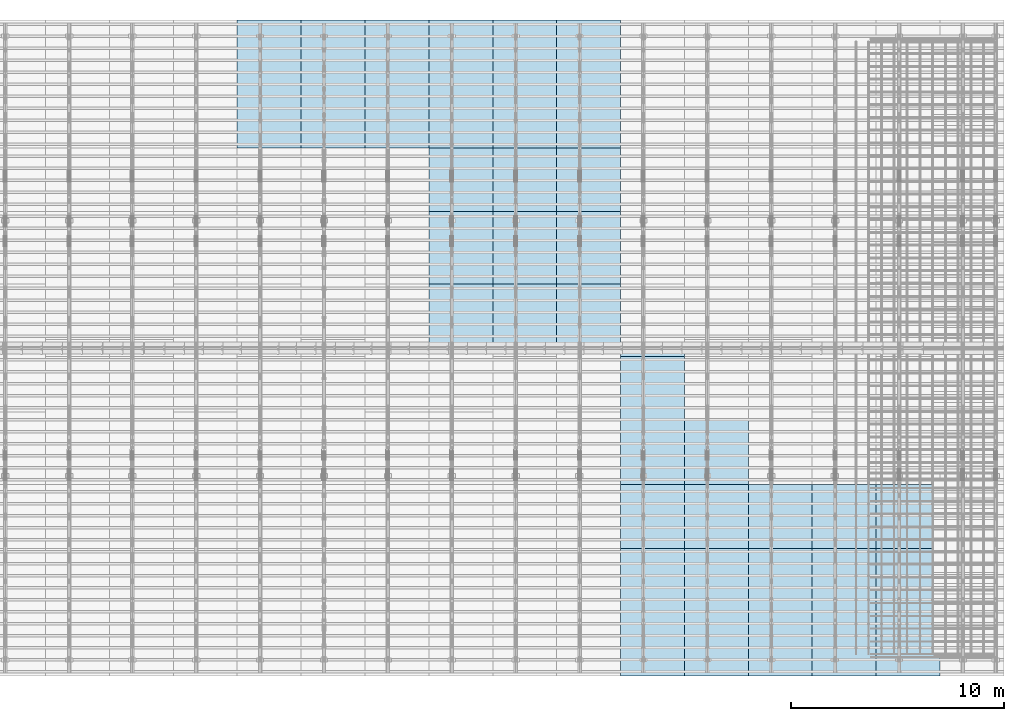
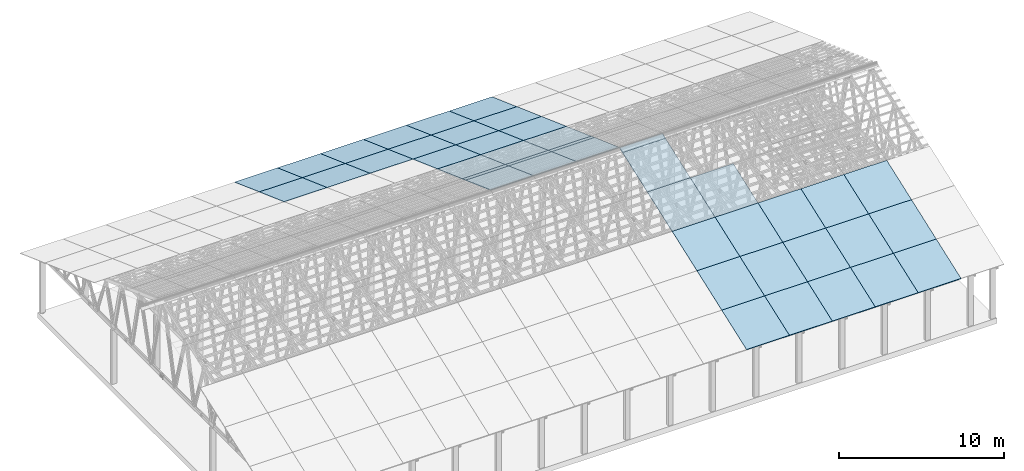
# One storey, part 8 of 189: 43 slabs, 43 elements without a shape of their own.
"""IFC2X3 building model written with IfcOpenShell, lengths in millimetres."""

from ifc_helpers import new_model, entity, si_unit, converted_unit, derived_unit, direction, frame, frame_2d, origin, place, context, subcontext, project, spatial, rectangle, extrude, material, layer, layer_set, element, aggregate, save


model = new_model("IFC2X3")

# Units and contexts
model_context = context("Model", 3, precision=0.01, world=origin(), true_north=direction((6.12303176911189e-17, 1.0)))
body_context = subcontext(model_context, "Body", "Model", "MODEL_VIEW")
ifc_project = project(units=[si_unit("LENGTHUNIT", "METRE", prefix="MILLI"), si_unit("AREAUNIT", "SQUARE_METRE"), si_unit("VOLUMEUNIT", "CUBIC_METRE"), converted_unit("PLANEANGLEUNIT", "DEGREE", entity("IfcRatioMeasure", 0.0174532925199433), si_unit("PLANEANGLEUNIT", "RADIAN"), dimensions=[0, 0, 0, 0, 0, 0, 0]), si_unit("MASSUNIT", "GRAM", prefix="KILO"), derived_unit("MASSDENSITYUNIT", [(si_unit("MASSUNIT", "GRAM", prefix="KILO"), 1), (si_unit("LENGTHUNIT", "METRE"), -3)]), si_unit("TIMEUNIT", "SECOND"), si_unit("FREQUENCYUNIT", "HERTZ"), si_unit("THERMODYNAMICTEMPERATUREUNIT", "DEGREE_CELSIUS"), derived_unit("THERMALTRANSMITTANCEUNIT", [(si_unit("MASSUNIT", "GRAM", prefix="KILO"), 1), (si_unit("THERMODYNAMICTEMPERATUREUNIT", "KELVIN"), -1), (si_unit("TIMEUNIT", "SECOND"), -3)]), derived_unit("VOLUMETRICFLOWRATEUNIT", [(si_unit("LENGTHUNIT", "METRE"), 3), (si_unit("TIMEUNIT", "SECOND"), -1)]), si_unit("ELECTRICCURRENTUNIT", "AMPERE"), si_unit("ELECTRICVOLTAGEUNIT", "VOLT"), si_unit("POWERUNIT", "WATT"), si_unit("FORCEUNIT", "NEWTON"), si_unit("ILLUMINANCEUNIT", "LUX"), si_unit("LUMINOUSFLUXUNIT", "LUMEN"), si_unit("LUMINOUSINTENSITYUNIT", "CANDELA"), derived_unit("USERDEFINED", [(si_unit("MASSUNIT", "GRAM", prefix="KILO"), -1), (si_unit("LENGTHUNIT", "METRE"), -2), (si_unit("TIMEUNIT", "SECOND"), 3), (si_unit("LUMINOUSFLUXUNIT", "LUMEN"), 1)]), derived_unit("LINEARVELOCITYUNIT", [(si_unit("LENGTHUNIT", "METRE"), 1), (si_unit("TIMEUNIT", "SECOND"), -1)]), si_unit("PRESSUREUNIT", "PASCAL"), derived_unit("USERDEFINED", [(si_unit("LENGTHUNIT", "METRE"), -2), (si_unit("MASSUNIT", "GRAM", prefix="KILO"), 1), (si_unit("TIMEUNIT", "SECOND"), -2)])], contexts=[model_context])

# Site, building, storey
site_placement = place(None, origin())
site = spatial("IfcSite", under=ifc_project, at=site_placement, CompositionType="ELEMENT")
building_placement = place(site_placement, origin())
building = spatial("IfcBuilding", under=site, at=building_placement, CompositionType="ELEMENT")
storey_placement = place(building_placement, origin())
storey = spatial("IfcBuildingStorey", under=building, at=storey_placement, Name="Default", CompositionType="ELEMENT", Elevation=0.0)

# Roof, slab
roof_1_placement = place(storey_placement, frame((44153.4200853155, -652.222549250817, 238.115215731819)))
roof_1 = element("IfcRoof", 1, at=roof_1_placement, inside=storey, ShapeType="NOTDEFINED")
ifc_material = material()
ifc_layer = layer(ifc_material, 40.0)
ifc_layer_set = layer_set([ifc_layer])
slab_1_placement = place(roof_1_placement, origin())
slab_1 = element("IfcSlab", 2, at=slab_1_placement, material=ifc_layer_set, PredefinedType="ROOF", context=body_context, shape_type="SweptSolid", body=[
    extrude(rectangle(XDim=3192.53331742773, YDim=2999.99999999999, at=frame_2d((0.0, -3.41060513164848e-13), x_axis=(0.0, -1.0))), frame((1500.0, 1500.0, 545.955351399302), z_axis=(0.0, -0.342020143325668, 0.939692620785909), x_axis=(1.0, 0.0, 0.0)), (0.0, 0.342020143325668, 0.939692620785909), 42.5671108990364),
])
aggregate(roof_1, [slab_1])

roof_2_placement = place(storey_placement, frame((44153.4200853155, 2347.77745074918, 1330.02591853042)))
roof_2 = element("IfcRoof", 3, at=roof_2_placement, inside=storey, ShapeType="NOTDEFINED")
slab_2_placement = place(roof_2_placement, origin())
slab_2 = element("IfcSlab", 4, at=slab_2_placement, material=ifc_layer_set, PredefinedType="ROOF", context=body_context, shape_type="SweptSolid", body=[
    extrude(rectangle(XDim=3192.53331742773, YDim=2999.99999999999, at=frame_2d((0.0, -1.13686837721616e-13), x_axis=(0.0, -1.0))), frame((1500.0, 1500.0, 545.955351399302), z_axis=(0.0, -0.342020143325668, 0.939692620785909), x_axis=(1.0, 0.0, 0.0)), (0.0, 0.342020143325668, 0.939692620785909), 42.5671108990353),
])
aggregate(roof_2, [slab_2])

roof_3_placement = place(storey_placement, frame((44153.4200853155, 5347.77745074918, 2421.93662132902)))
roof_3 = element("IfcRoof", 5, at=roof_3_placement, inside=storey, ShapeType="NOTDEFINED")
slab_3_placement = place(roof_3_placement, origin())
slab_3 = element("IfcSlab", 6, at=slab_3_placement, material=ifc_layer_set, PredefinedType="ROOF", context=body_context, shape_type="SweptSolid", body=[
    extrude(rectangle(XDim=3192.53331742773, YDim=2999.99999999999, at=frame_2d((0.0, 0.0), x_axis=(0.0, -1.0))), frame((1500.0, 1500.0, 545.955351399302), z_axis=(0.0, -0.342020143325668, 0.939692620785909), x_axis=(1.0, 0.0, 0.0)), (0.0, 0.342020143325668, 0.939692620785909), 42.5671108990355),
])
aggregate(roof_3, [slab_3])

roof_4_placement = place(storey_placement, frame((41153.4200853155, -652.222549250808, 238.115215731819)))
roof_4 = element("IfcRoof", 7, at=roof_4_placement, inside=storey, ShapeType="NOTDEFINED")
slab_4_placement = place(roof_4_placement, origin())
slab_4 = element("IfcSlab", 8, at=slab_4_placement, material=ifc_layer_set, PredefinedType="ROOF", context=body_context, shape_type="SweptSolid", body=[
    extrude(rectangle(XDim=3192.53331742773, YDim=2999.99999999999, at=frame_2d((0.0, -3.41060513164848e-13), x_axis=(0.0, -1.0))), frame((1500.0, 1500.0, 545.955351399302), z_axis=(0.0, -0.342020143325668, 0.939692620785909), x_axis=(1.0, 0.0, 0.0)), (0.0, 0.342020143325668, 0.939692620785909), 42.5671108990364),
])
aggregate(roof_4, [slab_4])

roof_5_placement = place(storey_placement, frame((41153.4200853155, 2347.77745074919, 1330.02591853042)))
roof_5 = element("IfcRoof", 9, at=roof_5_placement, inside=storey, ShapeType="NOTDEFINED")
slab_5_placement = place(roof_5_placement, origin())
slab_5 = element("IfcSlab", 10, at=slab_5_placement, material=ifc_layer_set, PredefinedType="ROOF", context=body_context, shape_type="SweptSolid", body=[
    extrude(rectangle(XDim=3192.53331742773, YDim=2999.99999999999, at=frame_2d((0.0, -1.13686837721616e-13), x_axis=(0.0, -1.0))), frame((1500.0, 1500.0, 545.955351399302), z_axis=(0.0, -0.342020143325668, 0.939692620785909), x_axis=(1.0, 0.0, 0.0)), (0.0, 0.342020143325668, 0.939692620785909), 42.5671108990353),
])
aggregate(roof_5, [slab_5])

roof_6_placement = place(storey_placement, frame((41153.4200853155, 5347.77745074919, 2421.93662132902)))
roof_6 = element("IfcRoof", 11, at=roof_6_placement, inside=storey, ShapeType="NOTDEFINED")
slab_6_placement = place(roof_6_placement, origin())
slab_6 = element("IfcSlab", 12, at=slab_6_placement, material=ifc_layer_set, PredefinedType="ROOF", context=body_context, shape_type="SweptSolid", body=[
    extrude(rectangle(XDim=3192.53331742773, YDim=2999.99999999999, at=frame_2d((0.0, 0.0), x_axis=(0.0, -1.0))), frame((1500.0, 1500.0, 545.955351399302), z_axis=(0.0, -0.342020143325668, 0.939692620785909), x_axis=(1.0, 0.0, 0.0)), (0.0, 0.342020143325668, 0.939692620785909), 42.5671108990355),
])
aggregate(roof_6, [slab_6])

roof_7_placement = place(storey_placement, frame((38153.4200853155, -652.222549250799, 238.115215731819)))
roof_7 = element("IfcRoof", 13, at=roof_7_placement, inside=storey, ShapeType="NOTDEFINED")
slab_7_placement = place(roof_7_placement, origin())
slab_7 = element("IfcSlab", 14, at=slab_7_placement, material=ifc_layer_set, PredefinedType="ROOF", context=body_context, shape_type="SweptSolid", body=[
    extrude(rectangle(XDim=3192.53331742773, YDim=2999.99999999999, at=frame_2d((0.0, -3.41060513164848e-13), x_axis=(0.0, -1.0))), frame((1500.0, 1500.0, 545.955351399302), z_axis=(0.0, -0.342020143325668, 0.939692620785909), x_axis=(1.0, 0.0, 0.0)), (0.0, 0.342020143325668, 0.939692620785909), 42.5671108990364),
])
aggregate(roof_7, [slab_7])

roof_8_placement = place(storey_placement, frame((38153.4200853155, 2347.7774507492, 1330.02591853042)))
roof_8 = element("IfcRoof", 15, at=roof_8_placement, inside=storey, ShapeType="NOTDEFINED")
slab_8_placement = place(roof_8_placement, origin())
slab_8 = element("IfcSlab", 16, at=slab_8_placement, material=ifc_layer_set, PredefinedType="ROOF", context=body_context, shape_type="SweptSolid", body=[
    extrude(rectangle(XDim=3192.53331742773, YDim=2999.99999999999, at=frame_2d((0.0, -1.13686837721616e-13), x_axis=(0.0, -1.0))), frame((1500.0, 1500.0, 545.955351399302), z_axis=(0.0, -0.342020143325668, 0.939692620785909), x_axis=(1.0, 0.0, 0.0)), (0.0, 0.342020143325668, 0.939692620785909), 42.5671108990353),
])
aggregate(roof_8, [slab_8])

roof_9_placement = place(storey_placement, frame((38153.4200853155, 5347.7774507492, 2421.93662132902)))
roof_9 = element("IfcRoof", 17, at=roof_9_placement, inside=storey, ShapeType="NOTDEFINED")
slab_9_placement = place(roof_9_placement, origin())
slab_9 = element("IfcSlab", 18, at=slab_9_placement, material=ifc_layer_set, PredefinedType="ROOF", context=body_context, shape_type="SweptSolid", body=[
    extrude(rectangle(XDim=3192.53331742773, YDim=2999.99999999999, at=frame_2d((0.0, 0.0), x_axis=(0.0, -1.0))), frame((1500.0, 1500.0, 545.955351399302), z_axis=(0.0, -0.342020143325668, 0.939692620785909), x_axis=(1.0, 0.0, 0.0)), (0.0, 0.342020143325668, 0.939692620785909), 42.5671108990355),
])
aggregate(roof_9, [slab_9])

roof_10_placement = place(storey_placement, frame((35153.4200853155, -652.222549250791, 238.115215731819)))
roof_10 = element("IfcRoof", 19, at=roof_10_placement, inside=storey, ShapeType="NOTDEFINED")
slab_10_placement = place(roof_10_placement, origin())
slab_10 = element("IfcSlab", 20, at=slab_10_placement, material=ifc_layer_set, PredefinedType="ROOF", context=body_context, shape_type="SweptSolid", body=[
    extrude(rectangle(XDim=3192.53331742773, YDim=2999.99999999999, at=frame_2d((0.0, -3.41060513164848e-13), x_axis=(0.0, -1.0))), frame((1500.0, 1500.0, 545.955351399302), z_axis=(0.0, -0.342020143325668, 0.939692620785909), x_axis=(1.0, 0.0, 0.0)), (0.0, 0.342020143325668, 0.939692620785909), 42.5671108990364),
])
aggregate(roof_10, [slab_10])

roof_11_placement = place(storey_placement, frame((35153.4200853156, 2347.77745074921, 1330.02591853042)))
roof_11 = element("IfcRoof", 21, at=roof_11_placement, inside=storey, ShapeType="NOTDEFINED")
slab_11_placement = place(roof_11_placement, origin())
slab_11 = element("IfcSlab", 22, at=slab_11_placement, material=ifc_layer_set, PredefinedType="ROOF", context=body_context, shape_type="SweptSolid", body=[
    extrude(rectangle(XDim=3192.53331742773, YDim=2999.99999999999, at=frame_2d((0.0, -1.13686837721616e-13), x_axis=(0.0, -1.0))), frame((1500.0, 1500.0, 545.955351399302), z_axis=(0.0, -0.342020143325668, 0.939692620785909), x_axis=(1.0, 0.0, 0.0)), (0.0, 0.342020143325668, 0.939692620785909), 42.5671108990353),
])
aggregate(roof_11, [slab_11])

roof_12_placement = place(storey_placement, frame((35153.4200853156, 5347.77745074921, 2421.93662132902)))
roof_12 = element("IfcRoof", 23, at=roof_12_placement, inside=storey, ShapeType="NOTDEFINED")
slab_12_placement = place(roof_12_placement, origin())
slab_12 = element("IfcSlab", 24, at=slab_12_placement, material=ifc_layer_set, PredefinedType="ROOF", context=body_context, shape_type="SweptSolid", body=[
    extrude(rectangle(XDim=3192.53331742773, YDim=2999.99999999999, at=frame_2d((0.0, 0.0), x_axis=(0.0, -1.0))), frame((1500.0, 1500.0, 545.955351399302), z_axis=(0.0, -0.342020143325668, 0.939692620785909), x_axis=(1.0, 0.0, 0.0)), (0.0, 0.342020143325668, 0.939692620785909), 42.5671108990355),
])
aggregate(roof_12, [slab_12])

roof_13_placement = place(storey_placement, frame((35153.4200853156, 8347.77745074922, 3513.84732412761)))
roof_13 = element("IfcRoof", 25, at=roof_13_placement, inside=storey, ShapeType="NOTDEFINED")
slab_13_placement = place(roof_13_placement, origin())
slab_13 = element("IfcSlab", 26, at=slab_13_placement, material=ifc_layer_set, PredefinedType="ROOF", context=body_context, shape_type="SweptSolid", body=[
    extrude(rectangle(XDim=3192.53331742773, YDim=2999.99999999999, at=frame_2d((0.0, 0.0), x_axis=(0.0, -1.0))), frame((1500.0, 1500.0, 545.955351399301), z_axis=(0.0, -0.342020143325668, 0.939692620785909), x_axis=(1.0, 0.0, 0.0)), (0.0, 0.342020143325668, 0.939692620785909), 42.5671108990366),
])
aggregate(roof_13, [slab_13])

roof_14_placement = place(storey_placement, frame((32153.4200853155, -652.222549250782, 238.115215731819)))
roof_14 = element("IfcRoof", 27, at=roof_14_placement, inside=storey, ShapeType="NOTDEFINED")
slab_14_placement = place(roof_14_placement, origin())
slab_14 = element("IfcSlab", 28, at=slab_14_placement, material=ifc_layer_set, PredefinedType="ROOF", context=body_context, shape_type="SweptSolid", body=[
    extrude(rectangle(XDim=3192.53331742773, YDim=2999.99999999999, at=frame_2d((0.0, -3.41060513164848e-13), x_axis=(0.0, -1.0))), frame((1500.0, 1500.0, 545.955351399302), z_axis=(0.0, -0.342020143325668, 0.939692620785909), x_axis=(1.0, 0.0, 0.0)), (0.0, 0.342020143325668, 0.939692620785909), 42.5671108990364),
])
aggregate(roof_14, [slab_14])

roof_15_placement = place(storey_placement, frame((32153.4200853156, 2347.77745074922, 1330.02591853042)))
roof_15 = element("IfcRoof", 29, at=roof_15_placement, inside=storey, ShapeType="NOTDEFINED")
slab_15_placement = place(roof_15_placement, origin())
slab_15 = element("IfcSlab", 30, at=slab_15_placement, material=ifc_layer_set, PredefinedType="ROOF", context=body_context, shape_type="SweptSolid", body=[
    extrude(rectangle(XDim=3192.53331742773, YDim=2999.99999999999, at=frame_2d((0.0, -1.13686837721616e-13), x_axis=(0.0, -1.0))), frame((1500.0, 1500.0, 545.955351399302), z_axis=(0.0, -0.342020143325668, 0.939692620785909), x_axis=(1.0, 0.0, 0.0)), (0.0, 0.342020143325668, 0.939692620785909), 42.5671108990353),
])
aggregate(roof_15, [slab_15])

roof_16_placement = place(storey_placement, frame((32153.4200853156, 5347.77745074922, 2421.93662132902)))
roof_16 = element("IfcRoof", 31, at=roof_16_placement, inside=storey, ShapeType="NOTDEFINED")
slab_16_placement = place(roof_16_placement, origin())
slab_16 = element("IfcSlab", 32, at=slab_16_placement, material=ifc_layer_set, PredefinedType="ROOF", context=body_context, shape_type="SweptSolid", body=[
    extrude(rectangle(XDim=3192.53331742773, YDim=2999.99999999999, at=frame_2d((0.0, 0.0), x_axis=(0.0, -1.0))), frame((1500.0, 1500.0, 545.955351399302), z_axis=(0.0, -0.342020143325668, 0.939692620785909), x_axis=(1.0, 0.0, 0.0)), (0.0, 0.342020143325668, 0.939692620785909), 42.5671108990355),
])
aggregate(roof_16, [slab_16])

roof_17_placement = place(storey_placement, frame((32153.4200853156, 8347.77745074923, 3513.84732412761)))
roof_17 = element("IfcRoof", 33, at=roof_17_placement, inside=storey, ShapeType="NOTDEFINED")
slab_17_placement = place(roof_17_placement, origin())
slab_17 = element("IfcSlab", 34, at=slab_17_placement, material=ifc_layer_set, PredefinedType="ROOF", context=body_context, shape_type="SweptSolid", body=[
    extrude(rectangle(XDim=3192.53331742773, YDim=2999.99999999999, at=frame_2d((0.0, 0.0), x_axis=(0.0, -1.0))), frame((1500.0, 1500.0, 545.955351399301), z_axis=(0.0, -0.342020143325668, 0.939692620785909), x_axis=(1.0, 0.0, 0.0)), (0.0, 0.342020143325668, 0.939692620785909), 42.5671108990366),
])
aggregate(roof_17, [slab_17])

roof_18_placement = place(storey_placement, frame((32153.4200853156, 11347.7774507492, 4605.75802692621)))
roof_18 = element("IfcRoof", 35, at=roof_18_placement, inside=storey, ShapeType="NOTDEFINED")
slab_18_placement = place(roof_18_placement, origin())
slab_18 = element("IfcSlab", 36, at=slab_18_placement, material=ifc_layer_set, PredefinedType="ROOF", context=body_context, shape_type="SweptSolid", body=[
    extrude(rectangle(XDim=3192.53331742773, YDim=2999.99999999999, at=frame_2d((0.0, 0.0), x_axis=(0.0, -1.0))), frame((1500.0, 1500.0, 545.955351399303), z_axis=(0.0, -0.342020143325669, 0.939692620785908), x_axis=(1.0, 0.0, 0.0)), (0.0, 0.342020143325669, 0.939692620785908), 42.5671108990361),
])
aggregate(roof_18, [slab_18])

roof_19_placement = place(storey_placement, frame((32153.4200853156, 11750.0000438631, 4752.15507836903)))
roof_19 = element("IfcRoof", 37, at=roof_19_placement, inside=storey, ShapeType="NOTDEFINED")
slab_19_placement = place(roof_19_placement, origin())
slab_19 = element("IfcSlab", 38, at=slab_19_placement, material=ifc_layer_set, PredefinedType="ROOF", context=body_context, shape_type="SweptSolid", body=[
    extrude(rectangle(XDim=3192.53331742773, YDim=2999.99999999999, at=frame_2d((0.0, 0.0), x_axis=(0.0, -1.0))), frame((1500.0, 1500.0, 545.955351399303), z_axis=(0.0, -0.342020143325669, 0.939692620785908), x_axis=(1.0, 0.0, 0.0)), (0.0, 0.342020143325669, 0.939692620785908), 42.5671108990361),
])
aggregate(roof_19, [slab_19])

roof_20_placement = place(storey_placement, frame((29153.4200853156, 27152.222636977, 238.115215731819)))
roof_20 = element("IfcRoof", 39, at=roof_20_placement, inside=storey, ShapeType="NOTDEFINED")
slab_20_placement = place(roof_20_placement, origin())
slab_20 = element("IfcSlab", 40, at=slab_20_placement, material=ifc_layer_set, PredefinedType="ROOF", context=body_context, shape_type="SweptSolid", body=[
    extrude(rectangle(XDim=3192.53331742773, YDim=2999.99999999999, at=frame_2d((-2.1600499167107e-12, 1.13686837721616e-13), x_axis=(0.0, 1.0))), frame((1500.0, 1500.0, 545.955351399304), z_axis=(0.0, 0.342020143325669, 0.939692620785908), x_axis=(1.0, 0.0, 0.0)), (0.0, -0.342020143325669, 0.939692620785908), 42.5671108990364),
])
aggregate(roof_20, [slab_20])

roof_21_placement = place(storey_placement, frame((29153.4200853156, 24152.222636977, 1330.02591853042)))
roof_21 = element("IfcRoof", 41, at=roof_21_placement, inside=storey, ShapeType="NOTDEFINED")
slab_21_placement = place(roof_21_placement, origin())
slab_21 = element("IfcSlab", 42, at=slab_21_placement, material=ifc_layer_set, PredefinedType="ROOF", context=body_context, shape_type="SweptSolid", body=[
    extrude(rectangle(XDim=3192.53331742773, YDim=2999.99999999999, at=frame_2d((-2.1600499167107e-12, 0.0), x_axis=(0.0, 1.0))), frame((1500.0, 1500.0, 545.955351399304), z_axis=(0.0, 0.342020143325669, 0.939692620785908), x_axis=(1.0, 0.0, 0.0)), (0.0, -0.342020143325669, 0.939692620785908), 42.5671108990358),
])
aggregate(roof_21, [slab_21])

roof_22_placement = place(storey_placement, frame((29153.4200853156, 21152.222636977, 2421.93662132902)))
roof_22 = element("IfcRoof", 43, at=roof_22_placement, inside=storey, ShapeType="NOTDEFINED")
slab_22_placement = place(roof_22_placement, origin())
slab_22 = element("IfcSlab", 44, at=slab_22_placement, material=ifc_layer_set, PredefinedType="ROOF", context=body_context, shape_type="SweptSolid", body=[
    extrude(rectangle(XDim=3192.53331742773, YDim=3000.0, at=frame_2d((2.1600499167107e-12, 1.13686837721616e-13), x_axis=(0.0, 1.0))), frame((1500.0, 1500.0, 545.955351399304), z_axis=(0.0, 0.342020143325669, 0.939692620785908), x_axis=(1.0, 0.0, 0.0)), (0.0, -0.342020143325669, 0.939692620785908), 42.5671108990361),
])
aggregate(roof_22, [slab_22])

roof_23_placement = place(storey_placement, frame((29153.4200853156, 18152.222636977, 3513.84732412761)))
roof_23 = element("IfcRoof", 45, at=roof_23_placement, inside=storey, ShapeType="NOTDEFINED")
slab_23_placement = place(roof_23_placement, origin())
slab_23 = element("IfcSlab", 46, at=slab_23_placement, material=ifc_layer_set, PredefinedType="ROOF", context=body_context, shape_type="SweptSolid", body=[
    extrude(rectangle(XDim=3192.53331742773, YDim=3000.0, at=frame_2d((2.1600499167107e-12, 0.0), x_axis=(0.0, 1.0))), frame((1500.0, 1500.0, 545.955351399303), z_axis=(0.0, 0.342020143325669, 0.939692620785908), x_axis=(1.0, 0.0, 0.0)), (0.0, -0.342020143325669, 0.939692620785908), 42.5671108990366),
])
aggregate(roof_23, [slab_23])

roof_24_placement = place(storey_placement, frame((29153.4200853156, 15152.222636977, 4605.75802692621)))
roof_24 = element("IfcRoof", 47, at=roof_24_placement, inside=storey, ShapeType="NOTDEFINED")
slab_24_placement = place(roof_24_placement, origin())
slab_24 = element("IfcSlab", 48, at=slab_24_placement, material=ifc_layer_set, PredefinedType="ROOF", context=body_context, shape_type="SweptSolid", body=[
    extrude(rectangle(XDim=3192.53331742773, YDim=3000.0, at=frame_2d((2.1600499167107e-12, -1.13686837721616e-13), x_axis=(0.0, 1.0))), frame((1500.0, 1500.0, 545.955351399304), z_axis=(0.0, 0.342020143325669, 0.939692620785908), x_axis=(1.0, 0.0, 0.0)), (0.0, -0.342020143325669, 0.939692620785908), 42.5671108990361),
])
aggregate(roof_24, [slab_24])

roof_25_placement = place(storey_placement, frame((29153.4200853156, 14750.0000438631, 4752.15507836903)))
roof_25 = element("IfcRoof", 49, at=roof_25_placement, inside=storey, ShapeType="NOTDEFINED")
slab_25_placement = place(roof_25_placement, origin())
slab_25 = element("IfcSlab", 50, at=slab_25_placement, material=ifc_layer_set, PredefinedType="ROOF", context=body_context, shape_type="SweptSolid", body=[
    extrude(rectangle(XDim=3192.53331742773, YDim=3000.0, at=frame_2d((2.1600499167107e-12, -1.13686837721616e-13), x_axis=(0.0, 1.0))), frame((1500.0, 1500.0, 545.955351399304), z_axis=(0.0, 0.342020143325669, 0.939692620785908), x_axis=(1.0, 0.0, 0.0)), (0.0, -0.342020143325669, 0.939692620785908), 42.5671108990361),
])
aggregate(roof_25, [slab_25])

roof_26_placement = place(storey_placement, frame((26153.4200853157, 27152.222636977, 238.115215731819)))
roof_26 = element("IfcRoof", 51, at=roof_26_placement, inside=storey, ShapeType="NOTDEFINED")
slab_26_placement = place(roof_26_placement, origin())
slab_26 = element("IfcSlab", 52, at=slab_26_placement, material=ifc_layer_set, PredefinedType="ROOF", context=body_context, shape_type="SweptSolid", body=[
    extrude(rectangle(XDim=3192.53331742773, YDim=2999.99999999999, at=frame_2d((-2.1600499167107e-12, 1.13686837721616e-13), x_axis=(0.0, 1.0))), frame((1500.0, 1500.0, 545.955351399304), z_axis=(0.0, 0.342020143325669, 0.939692620785908), x_axis=(1.0, 0.0, 0.0)), (0.0, -0.342020143325669, 0.939692620785908), 42.5671108990364),
])
aggregate(roof_26, [slab_26])

roof_27_placement = place(storey_placement, frame((26153.4200853156, 24152.222636977, 1330.02591853042)))
roof_27 = element("IfcRoof", 53, at=roof_27_placement, inside=storey, ShapeType="NOTDEFINED")
slab_27_placement = place(roof_27_placement, origin())
slab_27 = element("IfcSlab", 54, at=slab_27_placement, material=ifc_layer_set, PredefinedType="ROOF", context=body_context, shape_type="SweptSolid", body=[
    extrude(rectangle(XDim=3192.53331742773, YDim=2999.99999999999, at=frame_2d((-2.1600499167107e-12, 0.0), x_axis=(0.0, 1.0))), frame((1500.0, 1500.0, 545.955351399304), z_axis=(0.0, 0.342020143325669, 0.939692620785908), x_axis=(1.0, 0.0, 0.0)), (0.0, -0.342020143325669, 0.939692620785908), 42.5671108990358),
])
aggregate(roof_27, [slab_27])

roof_28_placement = place(storey_placement, frame((26153.4200853156, 21152.222636977, 2421.93662132902)))
roof_28 = element("IfcRoof", 55, at=roof_28_placement, inside=storey, ShapeType="NOTDEFINED")
slab_28_placement = place(roof_28_placement, origin())
slab_28 = element("IfcSlab", 56, at=slab_28_placement, material=ifc_layer_set, PredefinedType="ROOF", context=body_context, shape_type="SweptSolid", body=[
    extrude(rectangle(XDim=3192.53331742773, YDim=3000.0, at=frame_2d((2.1600499167107e-12, 1.13686837721616e-13), x_axis=(0.0, 1.0))), frame((1500.0, 1500.0, 545.955351399304), z_axis=(0.0, 0.342020143325669, 0.939692620785908), x_axis=(1.0, 0.0, 0.0)), (0.0, -0.342020143325669, 0.939692620785908), 42.5671108990361),
])
aggregate(roof_28, [slab_28])

roof_29_placement = place(storey_placement, frame((26153.4200853156, 18152.222636977, 3513.84732412761)))
roof_29 = element("IfcRoof", 57, at=roof_29_placement, inside=storey, ShapeType="NOTDEFINED")
slab_29_placement = place(roof_29_placement, origin())
slab_29 = element("IfcSlab", 58, at=slab_29_placement, material=ifc_layer_set, PredefinedType="ROOF", context=body_context, shape_type="SweptSolid", body=[
    extrude(rectangle(XDim=3192.53331742773, YDim=3000.0, at=frame_2d((2.1600499167107e-12, 0.0), x_axis=(0.0, 1.0))), frame((1500.0, 1500.0, 545.955351399303), z_axis=(0.0, 0.342020143325669, 0.939692620785908), x_axis=(1.0, 0.0, 0.0)), (0.0, -0.342020143325669, 0.939692620785908), 42.5671108990366),
])
aggregate(roof_29, [slab_29])

roof_30_placement = place(storey_placement, frame((26153.4200853156, 15152.222636977, 4605.75802692621)))
roof_30 = element("IfcRoof", 59, at=roof_30_placement, inside=storey, ShapeType="NOTDEFINED")
slab_30_placement = place(roof_30_placement, origin())
slab_30 = element("IfcSlab", 60, at=slab_30_placement, material=ifc_layer_set, PredefinedType="ROOF", context=body_context, shape_type="SweptSolid", body=[
    extrude(rectangle(XDim=3192.53331742773, YDim=3000.0, at=frame_2d((2.1600499167107e-12, -1.13686837721616e-13), x_axis=(0.0, 1.0))), frame((1500.0, 1500.0, 545.955351399304), z_axis=(0.0, 0.342020143325669, 0.939692620785908), x_axis=(1.0, 0.0, 0.0)), (0.0, -0.342020143325669, 0.939692620785908), 42.5671108990361),
])
aggregate(roof_30, [slab_30])

roof_31_placement = place(storey_placement, frame((26153.4200853156, 14750.0000438631, 4752.15507836903)))
roof_31 = element("IfcRoof", 61, at=roof_31_placement, inside=storey, ShapeType="NOTDEFINED")
slab_31_placement = place(roof_31_placement, origin())
slab_31 = element("IfcSlab", 62, at=slab_31_placement, material=ifc_layer_set, PredefinedType="ROOF", context=body_context, shape_type="SweptSolid", body=[
    extrude(rectangle(XDim=3192.53331742773, YDim=3000.0, at=frame_2d((2.1600499167107e-12, -1.13686837721616e-13), x_axis=(0.0, 1.0))), frame((1500.0, 1500.0, 545.955351399304), z_axis=(0.0, 0.342020143325669, 0.939692620785908), x_axis=(1.0, 0.0, 0.0)), (0.0, -0.342020143325669, 0.939692620785908), 42.5671108990361),
])
aggregate(roof_31, [slab_31])

roof_32_placement = place(storey_placement, frame((23153.4200853157, 27152.222636977, 238.115215731819)))
roof_32 = element("IfcRoof", 63, at=roof_32_placement, inside=storey, ShapeType="NOTDEFINED")
slab_32_placement = place(roof_32_placement, origin())
slab_32 = element("IfcSlab", 64, at=slab_32_placement, material=ifc_layer_set, PredefinedType="ROOF", context=body_context, shape_type="SweptSolid", body=[
    extrude(rectangle(XDim=3192.53331742773, YDim=2999.99999999999, at=frame_2d((-2.1600499167107e-12, 1.13686837721616e-13), x_axis=(0.0, 1.0))), frame((1500.0, 1500.0, 545.955351399304), z_axis=(0.0, 0.342020143325669, 0.939692620785908), x_axis=(1.0, 0.0, 0.0)), (0.0, -0.342020143325669, 0.939692620785908), 42.5671108990364),
])
aggregate(roof_32, [slab_32])

roof_33_placement = place(storey_placement, frame((23153.4200853156, 24152.222636977, 1330.02591853042)))
roof_33 = element("IfcRoof", 65, at=roof_33_placement, inside=storey, ShapeType="NOTDEFINED")
slab_33_placement = place(roof_33_placement, origin())
slab_33 = element("IfcSlab", 66, at=slab_33_placement, material=ifc_layer_set, PredefinedType="ROOF", context=body_context, shape_type="SweptSolid", body=[
    extrude(rectangle(XDim=3192.53331742773, YDim=2999.99999999999, at=frame_2d((-2.1600499167107e-12, 0.0), x_axis=(0.0, 1.0))), frame((1500.0, 1500.0, 545.955351399304), z_axis=(0.0, 0.342020143325669, 0.939692620785908), x_axis=(1.0, 0.0, 0.0)), (0.0, -0.342020143325669, 0.939692620785908), 42.5671108990358),
])
aggregate(roof_33, [slab_33])

roof_34_placement = place(storey_placement, frame((23153.4200853157, 21152.222636977, 2421.93662132902)))
roof_34 = element("IfcRoof", 67, at=roof_34_placement, inside=storey, ShapeType="NOTDEFINED")
slab_34_placement = place(roof_34_placement, origin())
slab_34 = element("IfcSlab", 68, at=slab_34_placement, material=ifc_layer_set, PredefinedType="ROOF", context=body_context, shape_type="SweptSolid", body=[
    extrude(rectangle(XDim=3192.53331742773, YDim=3000.0, at=frame_2d((2.1600499167107e-12, 1.13686837721616e-13), x_axis=(0.0, 1.0))), frame((1500.0, 1500.0, 545.955351399304), z_axis=(0.0, 0.342020143325669, 0.939692620785908), x_axis=(1.0, 0.0, 0.0)), (0.0, -0.342020143325669, 0.939692620785908), 42.5671108990361),
])
aggregate(roof_34, [slab_34])

roof_35_placement = place(storey_placement, frame((23153.4200853157, 18152.222636977, 3513.84732412761)))
roof_35 = element("IfcRoof", 69, at=roof_35_placement, inside=storey, ShapeType="NOTDEFINED")
slab_35_placement = place(roof_35_placement, origin())
slab_35 = element("IfcSlab", 70, at=slab_35_placement, material=ifc_layer_set, PredefinedType="ROOF", context=body_context, shape_type="SweptSolid", body=[
    extrude(rectangle(XDim=3192.53331742773, YDim=3000.0, at=frame_2d((2.1600499167107e-12, 0.0), x_axis=(0.0, 1.0))), frame((1500.0, 1500.0, 545.955351399303), z_axis=(0.0, 0.342020143325669, 0.939692620785908), x_axis=(1.0, 0.0, 0.0)), (0.0, -0.342020143325669, 0.939692620785908), 42.5671108990366),
])
aggregate(roof_35, [slab_35])

roof_36_placement = place(storey_placement, frame((23153.4200853157, 15152.222636977, 4605.75802692621)))
roof_36 = element("IfcRoof", 71, at=roof_36_placement, inside=storey, ShapeType="NOTDEFINED")
slab_36_placement = place(roof_36_placement, origin())
slab_36 = element("IfcSlab", 72, at=slab_36_placement, material=ifc_layer_set, PredefinedType="ROOF", context=body_context, shape_type="SweptSolid", body=[
    extrude(rectangle(XDim=3192.53331742773, YDim=3000.0, at=frame_2d((2.1600499167107e-12, -1.13686837721616e-13), x_axis=(0.0, 1.0))), frame((1500.0, 1500.0, 545.955351399304), z_axis=(0.0, 0.342020143325669, 0.939692620785908), x_axis=(1.0, 0.0, 0.0)), (0.0, -0.342020143325669, 0.939692620785908), 42.5671108990361),
])
aggregate(roof_36, [slab_36])

roof_37_placement = place(storey_placement, frame((23153.4200853157, 14750.0000438631, 4752.15507836903)))
roof_37 = element("IfcRoof", 73, at=roof_37_placement, inside=storey, ShapeType="NOTDEFINED")
slab_37_placement = place(roof_37_placement, origin())
slab_37 = element("IfcSlab", 74, at=slab_37_placement, material=ifc_layer_set, PredefinedType="ROOF", context=body_context, shape_type="SweptSolid", body=[
    extrude(rectangle(XDim=3192.53331742773, YDim=3000.0, at=frame_2d((2.1600499167107e-12, -1.13686837721616e-13), x_axis=(0.0, 1.0))), frame((1500.0, 1500.0, 545.955351399304), z_axis=(0.0, 0.342020143325669, 0.939692620785908), x_axis=(1.0, 0.0, 0.0)), (0.0, -0.342020143325669, 0.939692620785908), 42.5671108990361),
])
aggregate(roof_37, [slab_37])

roof_38_placement = place(storey_placement, frame((20153.4200853157, 27152.222636977, 238.115215731819)))
roof_38 = element("IfcRoof", 75, at=roof_38_placement, inside=storey, ShapeType="NOTDEFINED")
slab_38_placement = place(roof_38_placement, origin())
slab_38 = element("IfcSlab", 76, at=slab_38_placement, material=ifc_layer_set, PredefinedType="ROOF", context=body_context, shape_type="SweptSolid", body=[
    extrude(rectangle(XDim=3192.53331742773, YDim=2999.99999999999, at=frame_2d((-2.1600499167107e-12, 1.13686837721616e-13), x_axis=(0.0, 1.0))), frame((1500.0, 1500.0, 545.955351399304), z_axis=(0.0, 0.342020143325669, 0.939692620785908), x_axis=(1.0, 0.0, 0.0)), (0.0, -0.342020143325669, 0.939692620785908), 42.5671108990364),
])
aggregate(roof_38, [slab_38])

roof_39_placement = place(storey_placement, frame((20153.4200853157, 24152.222636977, 1330.02591853042)))
roof_39 = element("IfcRoof", 77, at=roof_39_placement, inside=storey, ShapeType="NOTDEFINED")
slab_39_placement = place(roof_39_placement, origin())
slab_39 = element("IfcSlab", 78, at=slab_39_placement, material=ifc_layer_set, PredefinedType="ROOF", context=body_context, shape_type="SweptSolid", body=[
    extrude(rectangle(XDim=3192.53331742773, YDim=2999.99999999999, at=frame_2d((-2.1600499167107e-12, 0.0), x_axis=(0.0, 1.0))), frame((1500.0, 1500.0, 545.955351399304), z_axis=(0.0, 0.342020143325669, 0.939692620785908), x_axis=(1.0, 0.0, 0.0)), (0.0, -0.342020143325669, 0.939692620785908), 42.5671108990358),
])
aggregate(roof_39, [slab_39])

roof_40_placement = place(storey_placement, frame((17153.4200853157, 27152.222636977, 238.115215731819)))
roof_40 = element("IfcRoof", 79, at=roof_40_placement, inside=storey, ShapeType="NOTDEFINED")
slab_40_placement = place(roof_40_placement, origin())
slab_40 = element("IfcSlab", 80, at=slab_40_placement, material=ifc_layer_set, PredefinedType="ROOF", context=body_context, shape_type="SweptSolid", body=[
    extrude(rectangle(XDim=3192.53331742773, YDim=2999.99999999999, at=frame_2d((0.0, 1.13686837721616e-13), x_axis=(0.0, 1.0))), frame((1500.0, 1500.0, 545.955351399304), z_axis=(0.0, 0.342020143325669, 0.939692620785908), x_axis=(1.0, 0.0, 0.0)), (0.0, -0.342020143325669, 0.939692620785908), 42.5671108990364),
])
aggregate(roof_40, [slab_40])

roof_41_placement = place(storey_placement, frame((17153.4200853157, 24152.222636977, 1330.02591853042)))
roof_41 = element("IfcRoof", 81, at=roof_41_placement, inside=storey, ShapeType="NOTDEFINED")
slab_41_placement = place(roof_41_placement, origin())
slab_41 = element("IfcSlab", 82, at=slab_41_placement, material=ifc_layer_set, PredefinedType="ROOF", context=body_context, shape_type="SweptSolid", body=[
    extrude(rectangle(XDim=3192.53331742773, YDim=2999.99999999999, at=frame_2d((0.0, 0.0), x_axis=(0.0, 1.0))), frame((1500.0, 1500.0, 545.955351399304), z_axis=(0.0, 0.342020143325669, 0.939692620785908), x_axis=(1.0, 0.0, 0.0)), (0.0, -0.342020143325669, 0.939692620785908), 42.5671108990358),
])
aggregate(roof_41, [slab_41])

roof_42_placement = place(storey_placement, frame((14153.4200853157, 27152.2226369771, 238.115215731819)))
roof_42 = element("IfcRoof", 83, at=roof_42_placement, inside=storey, ShapeType="NOTDEFINED")
slab_42_placement = place(roof_42_placement, origin())
slab_42 = element("IfcSlab", 84, at=slab_42_placement, material=ifc_layer_set, PredefinedType="ROOF", context=body_context, shape_type="SweptSolid", body=[
    extrude(rectangle(XDim=3192.53331742773, YDim=2999.99999999999, at=frame_2d((0.0, 1.13686837721616e-13), x_axis=(0.0, 1.0))), frame((1500.0, 1500.0, 545.955351399304), z_axis=(0.0, 0.342020143325669, 0.939692620785908), x_axis=(1.0, 0.0, 0.0)), (0.0, -0.342020143325669, 0.939692620785908), 42.5671108990364),
])
aggregate(roof_42, [slab_42])

roof_43_placement = place(storey_placement, frame((14153.4200853157, 24152.2226369771, 1330.02591853042)))
roof_43 = element("IfcRoof", 85, at=roof_43_placement, inside=storey, ShapeType="NOTDEFINED")
slab_43_placement = place(roof_43_placement, origin())
slab_43 = element("IfcSlab", 86, at=slab_43_placement, material=ifc_layer_set, PredefinedType="ROOF", context=body_context, shape_type="SweptSolid", body=[
    extrude(rectangle(XDim=3192.53331742773, YDim=2999.99999999999, at=frame_2d((0.0, 0.0), x_axis=(0.0, 1.0))), frame((1500.0, 1500.0, 545.955351399304), z_axis=(0.0, 0.342020143325669, 0.939692620785908), x_axis=(1.0, 0.0, 0.0)), (0.0, -0.342020143325669, 0.939692620785908), 42.5671108990358),
])
aggregate(roof_43, [slab_43])

save(model, "model.ifc")
